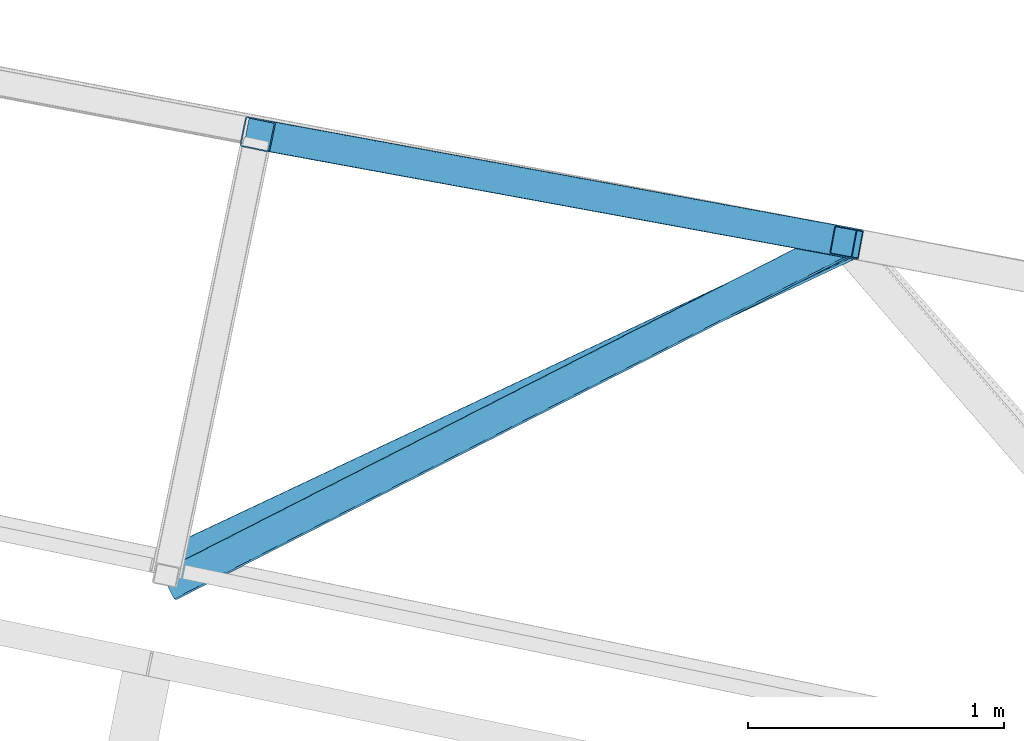
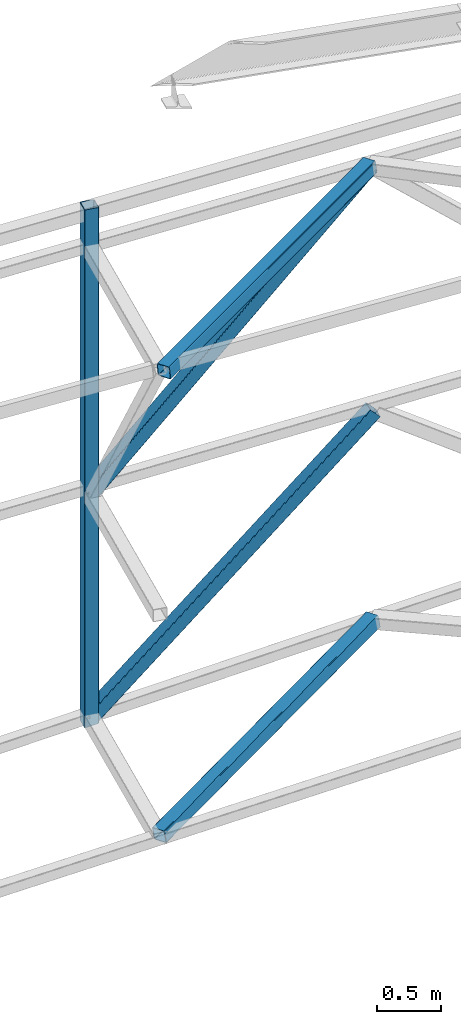
# One storey, part 96 of 215: 3 beams, 2 members, 5 elements without a shape of their own.
"""IFC2X3 building model written with IfcOpenShell, lengths in millimetres."""

from ifc_helpers import new_model, si_unit, frame, origin_with_axes, origin_2d_with_axis, place, context, subcontext, project, spatial, hollow_rectangle, extrude, clip, halfspace, material, type_object, element, aggregate, save


model = new_model("IFC2X3")

# Units and contexts
model_context = context("Model", 3, precision=1e-05, world=origin_with_axes())
body_context = subcontext(model_context, "Body", "Model", "MODEL_VIEW")
ifc_project = project(units=[si_unit("LENGTHUNIT", "METRE", prefix="MILLI"), si_unit("AREAUNIT", "SQUARE_METRE"), si_unit("VOLUMEUNIT", "CUBIC_METRE"), si_unit("MASSUNIT", "GRAM", prefix="KILO"), si_unit("TIMEUNIT", "SECOND"), si_unit("PLANEANGLEUNIT", "RADIAN"), si_unit("SOLIDANGLEUNIT", "STERADIAN"), si_unit("THERMODYNAMICTEMPERATUREUNIT", "DEGREE_CELSIUS"), si_unit("LUMINOUSINTENSITYUNIT", "LUMEN")], contexts=[model_context])

# Site, building, storey
site_placement = place(None, origin_with_axes())
site = spatial("IfcSite", under=ifc_project, at=site_placement, CompositionType="ELEMENT")
building_placement = place(site_placement, origin_with_axes())
building = spatial("IfcBuilding", under=site, at=building_placement, Name="Undefined", CompositionType="ELEMENT")
storey_placement = place(building_placement, origin_with_axes())
storey = spatial("IfcBuildingStorey", under=building, at=storey_placement, Name="Undefined", CompositionType="ELEMENT", Elevation=0.0)

# Assembly, beam
assembly_1_placement = place(storey_placement, origin_with_axes())
assembly_1 = element("IfcElementAssembly", 1, at=assembly_1_placement, inside=storey, Name="Steel Assembly", AssemblyPlace="NOTDEFINED", PredefinedType="RIGID_FRAME")
ifc_material_1 = material(Name="STEEL/S275JR")
beam_type = type_object("IfcBeamType", PredefinedType="NOTDEFINED")
beam_1_placement = place(assembly_1_placement, frame((75878.0323411126, 61726.8424594787, 10075.0880928738), z_axis=(-0.202744310094741, -0.979231711457614, -1.00000033900308e-09), x_axis=(0.0, 0.0, -1.0)))
beam_1 = element("IfcBeam", 2, at=beam_1_placement, type_object=beam_type, material=ifc_material_1, Name="MONTANT", context=body_context, shape_type="Clipping", body=[
    clip(extrude(hollow_rectangle(XDim=120.0, YDim=120.0, WallThickness=5.0, InnerFilletRadius=5.0, OuterFilletRadius=10.0, at=origin_2d_with_axis()), frame((4945.32758494818, 0.0, 1.45519152283669e-11), z_axis=(-1.0, 0.0, 0.0), x_axis=(-6.93889390390723e-18, -1.0, -3.46944695195361e-18)), (0.0, 0.0, 1.0), 4945.3), halfspace(frame((4947.92174686353, -77.3834914270119, 40.5943555733538), z_axis=(0.988050902406614, 0.154123414224719, -0.00117789693607931), x_axis=(0.0, -0.007642341407296, -0.999970796882496)), False)),
])
aggregate(assembly_1, [beam_1])

assembly_2_placement = place(storey_placement, origin_with_axes())
assembly_2 = element("IfcElementAssembly", 3, at=assembly_2_placement, inside=storey, Name="Steel Assembly", AssemblyPlace="NOTDEFINED", PredefinedType="RIGID_FRAME")
ifc_material_2 = material(Name="STEEL/S235JR")
beam_2_placement = place(assembly_2_placement, frame((75540.7347605439, 60049.5301316359, 5189.890265224), z_axis=(0.414818812923182, -0.90556100983229, 0.0887953259835557), x_axis=(0.897218905670844, 0.423321687844699, 0.125686052953891)))
beam_2 = element("IfcBeam", 4, at=beam_2_placement, type_object=beam_type, material=ifc_material_2, context=body_context, shape_type="SweptSolid", body=[
    extrude(hollow_rectangle(XDim=120.0, YDim=120.0, WallThickness=5.0, InnerFilletRadius=5.0, OuterFilletRadius=10.0, at=origin_2d_with_axis()), frame((2958.22995889925, -8.68441014116605e-13, -3.4583689235953e-12), z_axis=(-1.0, 0.0, 0.0), x_axis=(-6.93889390390723e-18, -1.0, -3.46944695195361e-18)), (0.0, 0.0, 1.0), 2958.2),
])
aggregate(assembly_2, [beam_2])

assembly_3_placement = place(storey_placement, origin_with_axes())
assembly_3 = element("IfcElementAssembly", 5, at=assembly_3_placement, inside=storey, Name="Steel Assembly", AssemblyPlace="NOTDEFINED", PredefinedType="RIGID_FRAME")
beam_3_placement = place(assembly_3_placement, frame((78168.6597167974, 61306.7571336141, 9905.27290340889), z_axis=(0.449125064049088, -0.891488897097426, 0.0594493330064972), x_axis=(-0.888308166935529, -0.452682526967145, -0.0773765489943842)))
beam_3 = element("IfcBeam", 6, at=beam_3_placement, type_object=beam_type, material=ifc_material_2, context=body_context, shape_type="SweptSolid", body=[
    extrude(hollow_rectangle(XDim=120.0, YDim=120.0, WallThickness=5.0, InnerFilletRadius=5.0, OuterFilletRadius=10.0, at=origin_2d_with_axis()), frame((2970.02000523552, -4.13530043468842e-13, 1.15923677112063e-13), z_axis=(-1.0, 0.0, 0.0), x_axis=(-6.93889390390723e-18, -1.0, -3.46944695195361e-18)), (0.0, 0.0, 1.0), 2970.0),
])
aggregate(assembly_3, [beam_3])

# Assembly, member
assembly_4_placement = place(storey_placement, origin_with_axes())
assembly_4 = element("IfcElementAssembly", 7, at=assembly_4_placement, inside=storey, Name="Steel Assembly", AssemblyPlace="NOTDEFINED", PredefinedType="RIGID_FRAME")
member_type = type_object("IfcMemberType", PredefinedType="NOTDEFINED")
member_1_placement = place(assembly_4_placement, frame((75878.0323374109, 61726.8424588159, 7330.67956749946), z_axis=(0.730202756128751, -0.137505673024245, -0.669250420118005), x_axis=(0.658276454153266, -0.120722112028109, 0.743033163173002)))
member_1 = element("IfcMember", 8, at=member_1_placement, type_object=member_type, material=ifc_material_2, context=body_context, shape_type="SweptSolid", body=[
    extrude(hollow_rectangle(XDim=120.0, YDim=120.0, WallThickness=5.0, InnerFilletRadius=5.0, OuterFilletRadius=10.0, at=origin_2d_with_axis()), frame((3478.37258799349, 1.46605274909254e-11, 0.0), z_axis=(-1.0, 0.0, 0.0), x_axis=(-6.93889390390723e-18, -1.0, -3.46944695195361e-18)), (0.0, 0.0, 1.0), 3478.4),
])
aggregate(assembly_4, [member_1])

assembly_5_placement = place(storey_placement, origin_with_axes())
assembly_5 = element("IfcElementAssembly", 9, at=assembly_5_placement, inside=storey, Name="Steel Assembly", AssemblyPlace="NOTDEFINED", PredefinedType="RIGID_FRAME")
member_2_placement = place(assembly_5_placement, frame((78194.9146074694, 61301.8130328687, 7564.89218162627), z_axis=(-0.698356325923663, 0.128115754985996, 0.70419087992303), x_axis=(-0.692632027297151, 0.127065614054512, -0.710010707304607)))
member_2 = element("IfcMember", 10, at=member_2_placement, type_object=member_type, material=ifc_material_2, context=body_context, shape_type="SweptSolid", body=[
    extrude(hollow_rectangle(XDim=120.0, YDim=120.0, WallThickness=5.0, InnerFilletRadius=5.0, OuterFilletRadius=10.0, at=origin_2d_with_axis()), frame((3345.03776808465, 7.79033068227514e-14, -7.27595761418343e-12), z_axis=(-1.0, 0.0, 0.0), x_axis=(-6.93889390390723e-18, -1.0, -3.46944695195361e-18)), (0.0, 0.0, 1.0), 3345.0),
])
aggregate(assembly_5, [member_2])

save(model, "model.ifc")
